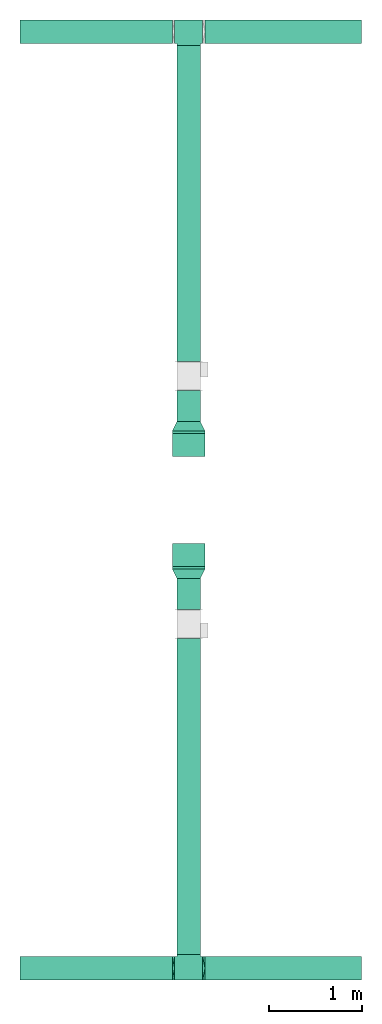
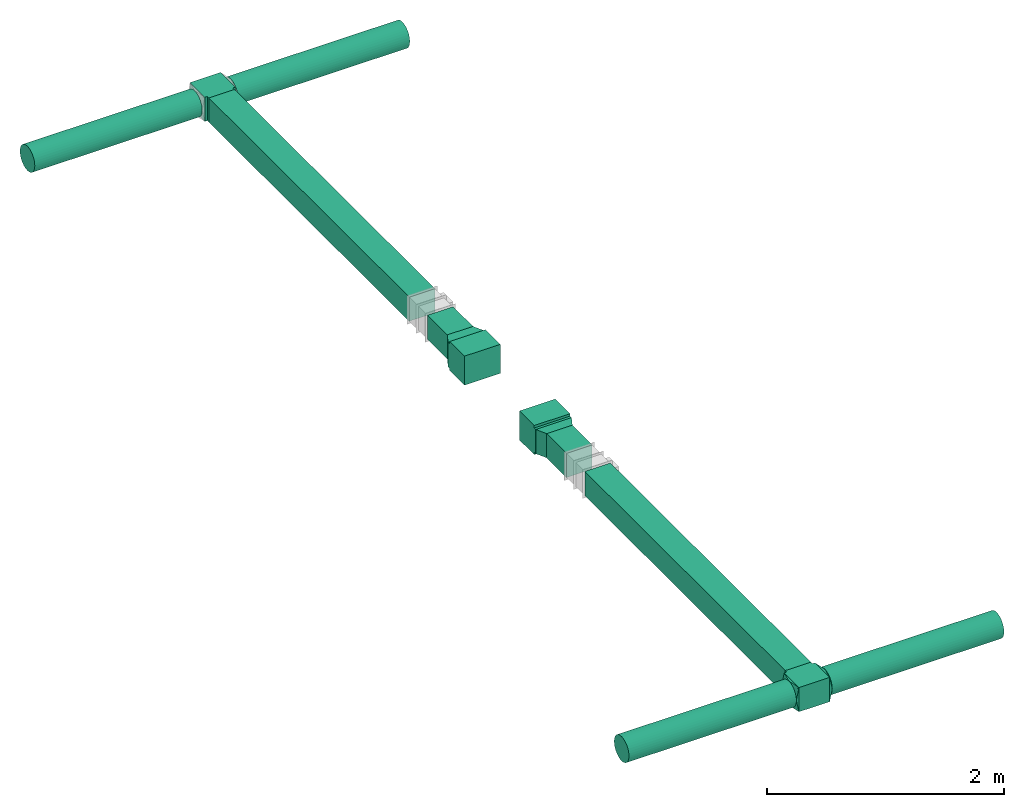
# One storey, part 1 of 3: 8 flow fittings, 8 flow segments.
"""IFC2X3 building model written with IfcOpenShell, lengths in millimetres."""

from ifc_helpers import new_model, entity, si_unit, converted_unit, derived_unit, direction, frame, frame_2d, origin, origin_2d_with_axis, place, context, subcontext, project, spatial, polyline, rectangle, circle, outline, extrude, faceted_brep, source, transform, mapped, material, type_object, type_shapes, element, save


model = new_model("IFC2X3")

# Units and contexts
model_context = context("Model", 3, precision=0.01, world=origin(), true_north=direction((6.12303176911189e-17, 1.0)))
body_context = subcontext(model_context, "Body", "Model", "MODEL_VIEW")
ifc_project = project(units=[si_unit("LENGTHUNIT", "METRE", prefix="MILLI"), si_unit("AREAUNIT", "SQUARE_METRE"), si_unit("VOLUMEUNIT", "CUBIC_METRE"), converted_unit("PLANEANGLEUNIT", "DEGREE", entity("IfcRatioMeasure", 0.0174532925199433), si_unit("PLANEANGLEUNIT", "RADIAN"), dimensions=[0, 0, 0, 0, 0, 0, 0]), si_unit("MASSUNIT", "GRAM", prefix="KILO"), derived_unit("MASSDENSITYUNIT", [(si_unit("MASSUNIT", "GRAM", prefix="KILO"), 1), (si_unit("LENGTHUNIT", "METRE"), -3)]), si_unit("TIMEUNIT", "SECOND"), si_unit("FREQUENCYUNIT", "HERTZ"), si_unit("THERMODYNAMICTEMPERATUREUNIT", "DEGREE_CELSIUS"), derived_unit("THERMALTRANSMITTANCEUNIT", [(si_unit("MASSUNIT", "GRAM", prefix="KILO"), 1), (si_unit("THERMODYNAMICTEMPERATUREUNIT", "KELVIN"), -1), (si_unit("TIMEUNIT", "SECOND"), -3)]), derived_unit("VOLUMETRICFLOWRATEUNIT", [(si_unit("LENGTHUNIT", "METRE"), 3), (si_unit("TIMEUNIT", "SECOND"), -1)]), si_unit("ELECTRICCURRENTUNIT", "AMPERE"), si_unit("ELECTRICVOLTAGEUNIT", "VOLT"), si_unit("POWERUNIT", "WATT"), si_unit("FORCEUNIT", "NEWTON", prefix="KILO"), si_unit("ILLUMINANCEUNIT", "LUX"), si_unit("LUMINOUSFLUXUNIT", "LUMEN"), si_unit("LUMINOUSINTENSITYUNIT", "CANDELA"), derived_unit("USERDEFINED", [(si_unit("MASSUNIT", "GRAM", prefix="KILO"), -1), (si_unit("LENGTHUNIT", "METRE"), -2), (si_unit("TIMEUNIT", "SECOND"), 3), (si_unit("LUMINOUSFLUXUNIT", "LUMEN"), 1)]), derived_unit("LINEARVELOCITYUNIT", [(si_unit("LENGTHUNIT", "METRE"), 1), (si_unit("TIMEUNIT", "SECOND"), -1)]), si_unit("PRESSUREUNIT", "PASCAL"), derived_unit("USERDEFINED", [(si_unit("LENGTHUNIT", "METRE"), -2), (si_unit("MASSUNIT", "GRAM", prefix="KILO"), 1), (si_unit("TIMEUNIT", "SECOND"), -2)])], contexts=[model_context])

# Site, building, storey
site_placement = place(None, origin())
site = spatial("IfcSite", under=ifc_project, at=site_placement, CompositionType="ELEMENT")
building_placement = place(site_placement, origin())
building = spatial("IfcBuilding", under=site, at=building_placement, CompositionType="ELEMENT")
storey_placement = place(building_placement, frame((0.0, 0.0, 8000.0)))
storey = spatial("IfcBuildingStorey", under=building, at=storey_placement, Name="02 Level", CompositionType="ELEMENT", Elevation=8000.0)

# Flow segments
duct_segment_type_1 = type_object("IfcDuctSegmentType", Name="Round Duct:Air", PredefinedType="NOTDEFINED")
flow_segment_1_placement = place(storey_placement, frame((24805.6615179764, -73978.4971681894, 3383.40472776408)))
element("IfcFlowSegment", 1, at=flow_segment_1_placement, inside=storey, type_object=duct_segment_type_1, Name="Round Duct:Air", ObjectType="Round Duct:Air", context=body_context, shape_type="SweptSolid", body=[
    extrude(circle(Radius=125.0, at=origin_2d_with_axis()), frame((0.0, 126.595272235913, 126.595272235916), z_axis=(1.0, 0.0, 0.0), x_axis=(0.0, -1.0, 0.0)), (0.0, 0.0, 1.0), 1675.67988537007),
])
flow_segment_2_placement = place(storey_placement, frame((22822.2515072766, -73978.4971681894, 3383.40472776408)))
element("IfcFlowSegment", 2, at=flow_segment_2_placement, inside=storey, type_object=duct_segment_type_1, Name="Round Duct:Air", ObjectType="Round Duct:Air", context=body_context, shape_type="SweptSolid", body=[
    extrude(circle(Radius=125.0, at=origin_2d_with_axis()), frame((0.0, 126.595272235913, 126.595272235916), z_axis=(1.0, 0.0, 0.0), x_axis=(0.0, -1.0, 0.0)), (0.0, 0.0, 1.0), 1633.4100106998),
])
flow_segment_3_placement = place(storey_placement, frame((24805.6615179764, -63937.1725465623, 3383.40472776408)))
element("IfcFlowSegment", 3, at=flow_segment_3_placement, inside=storey, type_object=duct_segment_type_1, Name="Round Duct:Air", ObjectType="Round Duct:Air", context=body_context, shape_type="SweptSolid", body=[
    extrude(circle(Radius=125.0, at=origin_2d_with_axis()), frame((0.0, 126.595272235922, 126.595272235916), z_axis=(1.0, 0.0, 0.0), x_axis=(0.0, -1.0, 0.0)), (0.0, 0.0, 1.0), 1675.67988537007),
])
flow_segment_4_placement = place(storey_placement, frame((22822.2515072766, -63937.1725465622, 3383.40472776408)))
element("IfcFlowSegment", 4, at=flow_segment_4_placement, inside=storey, type_object=duct_segment_type_1, Name="Round Duct:Air", ObjectType="Round Duct:Air", context=body_context, shape_type="SweptSolid", body=[
    extrude(circle(Radius=125.0, at=origin_2d_with_axis()), frame((0.0, 126.595272235922, 126.595272235916), z_axis=(1.0, 0.0, 0.0), x_axis=(0.0, -1.0, 0.0)), (0.0, 0.0, 1.0), 1633.4100106998),
])
duct_segment_type_2 = type_object("IfcDuctSegmentType", Name="Rectangular Duct:Air", PredefinedType="NOTDEFINED")
flow_segment_5_placement = place(storey_placement, frame((24505.6615179764, -70005.2893332731, 3385.0)))
element("IfcFlowSegment", 5, at=flow_segment_5_placement, inside=storey, type_object=duct_segment_type_2, Name="Rectangular Duct:Air", ObjectType="Rectangular Duct:Air", context=body_context, shape_type="SweptSolid", body=[
    extrude(rectangle(XDim=334.049748133151, YDim=249.999999999999, at=frame_2d((4.33431068813661e-12, 2.16715534406831e-12), x_axis=(1.0, 0.0))), frame((125.0, 167.02487406658, 0.0), z_axis=(0.0, 0.0, 1.0), x_axis=(0.0, 1.0, 0.0)), (0.0, 0.0, 1.0), 249.999999999999),
])
flow_segment_6_placement = place(storey_placement, frame((24505.6615179764, -73701.9018959535, 3385.0)))
element("IfcFlowSegment", 6, at=flow_segment_6_placement, inside=storey, type_object=duct_segment_type_2, Name="Rectangular Duct:Air", ObjectType="Rectangular Duct:Air", context=body_context, shape_type="SweptSolid", body=[
    extrude(rectangle(XDim=3386.61256268045, YDim=249.999999999999, at=frame_2d((4.32009983342141e-12, 0.0), x_axis=(1.0, 0.0))), frame((125.0, 1693.30628134022, 0.0), z_axis=(0.0, 0.0, 1.0), x_axis=(0.0, 1.0, 0.0)), (0.0, 0.0, 1.0), 249.999999999999),
])
flow_segment_7_placement = place(storey_placement, frame((24505.6615179764, -67991.2395851399, 3385.0)))
element("IfcFlowSegment", 7, at=flow_segment_7_placement, inside=storey, type_object=duct_segment_type_2, Name="Rectangular Duct:Air", ObjectType="Rectangular Duct:Air", context=body_context, shape_type="SweptSolid", body=[
    extrude(rectangle(XDim=334.049748133151, YDim=249.999999999999, at=frame_2d((8.66862137627322e-12, 0.0), x_axis=(1.0, 0.0))), frame((125.0, 167.024874066589, 0.0), z_axis=(0.0, 0.0, 1.0), x_axis=(0.0, -1.0, 0.0)), (0.0, 0.0, 1.0), 249.999999999999),
])
flow_segment_8_placement = place(storey_placement, frame((24505.6615179764, -67347.1898370068, 3385.0)))
element("IfcFlowSegment", 8, at=flow_segment_8_placement, inside=storey, type_object=duct_segment_type_2, Name="Rectangular Duct:Air", ObjectType="Rectangular Duct:Air", context=body_context, shape_type="SweptSolid", body=[
    extrude(rectangle(XDim=3386.61256268045, YDim=249.999999999999, at=frame_2d((4.32009983342141e-12, 2.16715534406831e-12), x_axis=(1.0, 0.0))), frame((125.0, 1693.30628134022, 0.0), z_axis=(0.0, 0.0, 1.0), x_axis=(0.0, -1.0, 0.0)), (0.0, 0.0, 1.0), 249.999999999999),
])

# Flow fittings
duct_fitting_type_1 = type_object("IfcDuctFittingType", Name="Air_Rect", PredefinedType="NOTDEFINED")
shared_shape_1 = source(origin(), body_context, "Body", "SweptSolid", [
    extrude(outline(polyline([(-150.0, 56.2500000000001), (-150.0, -193.75), (150.0, -193.75), (150.0, 56.25), (125.0, 56.25), (125.0, 81.2499999999995), (-125.0, 81.2500000000003), (-125.0, 56.2500000000001), (-150.0, 56.2500000000001)])), frame((0.0, -68.75, -125.0), z_axis=(0.0, 0.0, -1.0), x_axis=(1.0, 0.0, 0.0)), (0.0, 0.0, -1.0), 250.0),
])
type_shapes(duct_fitting_type_1, [shared_shape_1])
flow_fitting_1_placement = place(storey_placement, frame((24630.6615179764, -73851.9018959535, 3510.0), z_axis=(0.0, 0.0, 1.0), x_axis=(-1.0, 0.0, 0.0)))
element("IfcFlowFitting", 9, at=flow_fitting_1_placement, inside=storey, type_object=duct_fitting_type_1, Name="1_001:Air_Rect", ObjectType="1_001:Air_Rect", context=body_context, shape_type="MappedRepresentation", body=[
    mapped(shared_shape_1, transform((0.0, 0.0, 0.0), scale=1.0)),
])
ifc_material_1 = material(Name="Material_Duct")
duct_fitting_type_2 = type_object("IfcDuctFittingType", Name="Air_Multi shape transition_Circ", PredefinedType="NOTDEFINED", material=ifc_material_1)
shared_shape_2 = source(origin(), body_context, "Body", "Brep", [
    faceted_brep([(25.0, -38.627124296869, -118.882064536893), (25.0, -23.8439039196152, -121.223496622539), (25.0, -11.9219519598079, -123.111748311269), (25.0, -5.96097597990422, -124.055874155634), (25.0, 0.0, -125.0), (25.0, 5.9609759747813, -124.055874156445), (25.0, 11.9219519495628, -123.111748312892), (25.0, 23.8439038991258, -121.223496625784), (25.0, 38.6271242968683, -118.882064536893), (25.0, 56.0501404167137, -110.00459441688), (25.0, 73.4731565365591, -101.127124296868), (25.0, 87.3001404167137, -87.3001404167129), (25.0, 101.127124296868, -73.4731565365583), (25.0, 110.004594416881, -56.0501404167129), (25.0, 118.882064536894, -38.6271242968675), (25.0, 121.22349662254, -23.8439039196137), (25.0, 123.11174831127, -11.9219519598064), (25.0, 124.055874155635, -5.96097597990274), (25.0, 125.0, 0.0), (25.0, 124.055874156446, 5.96097597478117), (25.0, 123.111748312892, 11.9219519495627), (25.0, 121.223496625785, 23.8439038991257), (25.0, 118.882064536894, 38.6271242968681), (25.0, 110.004594416881, 56.0501404167135), (25.0, 101.127124296869, 73.4731565365589), (25.0, 87.300140416714, 87.3001404167136), (25.0, 73.4731565365594, 101.127124296868), (25.0, 56.050140416714, 110.004594416881), (25.0, 38.6271242968687, 118.882064536894), (25.0, 23.8439039196148, 121.22349662254), (25.0, 11.9219519598075, 123.11174831127), (25.0, 5.96097597990388, 124.055874155635), (25.0, 0.0, 125.0), (25.0, -5.96097597478126, 124.055874156446), (25.0, -11.9219519495628, 123.111748312892), (25.0, -23.8439038991258, 121.223496625785), (25.0, -38.6271242968682, 118.882064536894), (25.0, -56.0501404167136, 110.004594416881), (25.0, -73.473156536559, 101.127124296869), (25.0, -87.3001404167137, 87.3001404167139), (25.0, -101.127124296868, 73.4731565365593), (25.0, -110.004594416881, 56.0501404167139), (25.0, -118.882064536894, 38.6271242968685), (25.0, -121.22349662254, 23.8439039196147), (25.0, -123.11174831127, 11.9219519598073), (25.0, -124.055874155635, 5.96097597990369), (25.0, -125.0, 0.0), (25.0, -124.055874156446, -5.96097597478013), (25.0, -123.111748312892, -11.9219519495616), (25.0, -121.223496625785, -23.8439038991246), (25.0, -118.882064536894, -38.6271242968671), (25.0, -110.004594416882, -56.0501404167124), (25.0, -101.127124296869, -73.4731565365578), (25.0, -87.3001404167141, -87.3001404167125), (25.0, -73.4731565365595, -101.127124296867), (25.0, -56.0501404167142, -110.00459441688), (0.0, -125.0, 125.0), (0.0, 125.0, 125.0), (0.0, 125.0, -125.0), (0.0, -125.0, -125.0), (13.0142783389037, -59.9286083054818, 125.0), (12.4999999334883, -103.93826768006, 109.288032538106), (3.25356958472593, -108.732152076371, 125.0), (9.76070875417778, -76.1964562291116, 125.0), (6.50713916945186, -92.4643041527413, 125.0), (23.501784792363, -7.49107603818501, 125.0), (22.0035695847259, -14.9821520763703, 125.0), (19.0071391694519, -29.9643041527408, 125.0), (16.0107087541778, -44.9464562291113, 125.0), (6.50713897169544, -125.0, 92.464305141524), (9.76070845754317, -125.0, 76.1964577122852), (13.0142779433909, -125.0, 59.9286102830464), (16.0107084575432, -125.0, 44.9464577122848), (19.0071389716954, -125.0, 29.9643051415232), (22.0035694858477, -125.0, 14.9821525707616), (23.5017847429239, -125.0, 7.49107628538082), (3.25356948584772, -125.0, 108.732152570763), (3.25356958472593, -125.0, -108.73215207637), (6.50713916945185, -125.0, -92.4643041527404), (9.76070875417777, -125.0, -76.1964562291106), (13.0142783389037, -125.0, -59.9286083054808), (16.0107087541778, -125.0, -44.9464562291103), (19.0071391694518, -125.0, -29.9643041527397), (22.0035695847259, -125.0, -14.9821520763692), (23.501784792363, -125.0, -7.4910760381839), (12.4999999334883, -109.288032538106, -103.938267680059), (6.50713897169543, -92.4643051415237, -125.0), (9.76070845754315, -76.196457712285, -125.0), (13.0142779433909, -59.9286102830464, -125.0), (16.0107084575432, -44.9464577122849, -125.0), (19.0071389716954, -29.9643051415235, -125.0), (22.0035694858477, -14.982152570762, -125.0), (23.5017847429239, -7.49107628538127, -125.0), (3.25356948584772, -108.732152570762, -125.0), (3.25356958472593, 108.73215207637, -125.0), (6.50713916945186, 92.4643041527402, -125.0), (9.76070875417778, 76.1964562291106, -125.0), (13.0142783389037, 59.9286083054811, -125.0), (16.0107087541778, 44.9464562291108, -125.0), (19.0071391694519, 29.9643041527404, -125.0), (22.0035695847259, 14.9821520763701, -125.0), (23.501784792363, 7.49107603818496, -125.0), (12.4999999334883, 103.938267680059, -109.288032538105), (6.50713897169544, 125.0, -92.4643051415225), (9.76070845754317, 125.0, -76.1964577122838), (13.0142779433909, 125.0, -59.9286102830451), (16.0107084575432, 125.0, -44.9464577122836), (19.0071389716954, 125.0, -29.9643051415221), (22.0035694858477, 125.0, -14.9821525707606), (23.5017847429239, 125.0, -7.49107628537983), (3.25356948584772, 125.0, -108.732152570761), (3.25356958472593, 125.0, 108.732152076372), (6.50713916945185, 125.0, 92.4643041527418), (9.76070875417778, 125.0, 76.196456229112), (13.0142783389037, 125.0, 59.9286083054821), (16.0107087541778, 125.0, 44.9464562291115), (19.0071391694519, 125.0, 29.9643041527409), (22.0035695847259, 125.0, 14.9821520763703), (23.501784792363, 125.0, 7.49107603818497), (12.4999999334883, 109.288032538105, 103.93826768006), (6.50713897169544, 92.4643051415224, 125.0), (9.76070845754316, 76.1964577122839, 125.0), (13.0142779433909, 59.9286102830454, 125.0), (16.0107084575432, 44.9464577122841, 125.0), (19.0071389716954, 29.9643051415228, 125.0), (22.0035694858477, 14.9821525707615, 125.0), (23.5017847429239, 7.49107628538087, 125.0), (3.25356948584772, 108.732152570761, 125.0)], [[[0, 1, 2, 3, 4, 5, 6, 7, 8, 9, 10, 11, 12, 13, 14, 15, 16, 17, 18, 19, 20, 21, 22, 23, 24, 25, 26, 27, 28, 29, 30, 31, 32, 33, 34, 35, 36, 37, 38, 39, 40, 41, 42, 43, 44, 45, 46, 47, 48, 49, 50, 51, 52, 53, 54, 55]], [[56, 57, 58, 59]], [[60, 37, 36]], [[56, 61, 62]], [[37, 60, 63, 64]], [[65, 66, 67, 68, 60, 36, 35, 34, 33, 32]], [[62, 61, 38]], [[41, 69, 70, 71]], [[64, 38, 37]], [[42, 71, 72, 73, 74, 75, 46, 45, 44, 43]], [[40, 76, 69]], [[71, 42, 41]], [[61, 76, 39]], [[38, 64, 62]], [[76, 40, 39]], [[38, 61, 39]], [[61, 56, 76]], [[69, 41, 40]], [[56, 59, 77, 78, 79, 80, 81, 82, 83, 84, 46, 75, 74, 73, 72, 71, 70, 69, 76]], [[80, 51, 50]], [[59, 85, 77]], [[51, 80, 79, 78]], [[84, 83, 82, 81, 80, 50, 49, 48, 47, 46]], [[77, 85, 52]], [[55, 86, 87, 88]], [[78, 52, 51]], [[0, 88, 89, 90, 91, 92, 4, 3, 2, 1]], [[54, 93, 86]], [[88, 0, 55]], [[85, 93, 53]], [[52, 78, 77]], [[93, 54, 53]], [[52, 85, 53]], [[85, 59, 93]], [[86, 55, 54]], [[92, 91, 90, 89, 88, 87, 86, 93, 59, 58, 94, 95, 96, 97, 98, 99, 100, 101, 4]], [[97, 9, 8]], [[58, 102, 94]], [[9, 97, 96, 95]], [[101, 100, 99, 98, 97, 8, 7, 6, 5, 4]], [[94, 102, 10]], [[13, 103, 104, 105]], [[95, 10, 9]], [[14, 105, 106, 107, 108, 109, 18, 17, 16, 15]], [[12, 110, 103]], [[105, 14, 13]], [[102, 110, 11]], [[10, 95, 94]], [[110, 12, 11]], [[10, 102, 11]], [[102, 58, 110]], [[103, 13, 12]], [[58, 57, 111, 112, 113, 114, 115, 116, 117, 118, 18, 109, 108, 107, 106, 105, 104, 103, 110]], [[114, 23, 22]], [[57, 119, 111]], [[23, 114, 113, 112]], [[118, 117, 116, 115, 114, 22, 21, 20, 19, 18]], [[111, 119, 24]], [[27, 120, 121, 122]], [[112, 24, 23]], [[28, 122, 123, 124, 125, 126, 32, 31, 30, 29]], [[26, 127, 120]], [[122, 28, 27]], [[119, 127, 25]], [[24, 112, 111]], [[127, 26, 25]], [[24, 119, 25]], [[119, 57, 127]], [[120, 27, 26]], [[57, 56, 62, 64, 63, 60, 68, 67, 66, 65, 32, 126, 125, 124, 123, 122, 121, 120, 127]]]),
])
type_shapes(duct_fitting_type_2, [shared_shape_2])
flow_fitting_2_placement = place(storey_placement, frame((24480.6615179764, -73851.9018959535, 3510.0), z_axis=(0.0, 0.0, 1.0), x_axis=(-1.0, 0.0, 0.0)))
element("IfcFlowFitting", 10, at=flow_fitting_2_placement, inside=storey, type_object=duct_fitting_type_2, material=ifc_material_1, Name="multi_shape_trans_001:Air_Multi shape transition_Circ", ObjectType="multi_shape_trans_001:Air_Multi shape transition_Circ", context=body_context, shape_type="MappedRepresentation", body=[
    mapped(shared_shape_2, transform((0.0, 0.0, 0.0), scale=1.0)),
])
flow_fitting_3_placement = place(storey_placement, frame((24780.6615179764, -73851.9018959535, 3510.0)))
element("IfcFlowFitting", 11, at=flow_fitting_3_placement, inside=storey, type_object=duct_fitting_type_2, material=ifc_material_1, Name="multi_shape_trans_001:Air_Multi shape transition_Circ", ObjectType="multi_shape_trans_001:Air_Multi shape transition_Circ", context=body_context, shape_type="MappedRepresentation", body=[
    mapped(shared_shape_2, transform((0.0, 0.0, 0.0), scale=1.0)),
])
duct_fitting_type_3 = type_object("IfcDuctFittingType", Name="Air_Rect", PredefinedType="NOTDEFINED")
shared_shape_3 = source(origin(), body_context, "Body", "SweptSolid", [
    extrude(outline(polyline([(-150.0, 56.2500000000001), (-150.0, -193.75), (150.0, -193.75), (150.0, 56.25), (125.0, 56.25), (125.0, 81.2499999999995), (-125.0, 81.2500000000003), (-125.0, 56.2500000000001), (-150.0, 56.2500000000001)])), frame((0.0, -68.75, -175.0), z_axis=(0.0, 0.0, -1.0), x_axis=(1.0, 0.0, 0.0)), (0.0, 0.0, -1.0), 350.0),
])
type_shapes(duct_fitting_type_3, [shared_shape_3])
flow_fitting_4_placement = place(storey_placement, frame((24630.6615179764, -69421.2395851399, 3510.0), z_axis=(1.0, 0.0, 0.0), x_axis=(0.0, 0.0, -1.0)))
element("IfcFlowFitting", 12, at=flow_fitting_4_placement, inside=storey, type_object=duct_fitting_type_3, Name="1_001:Air_Rect", ObjectType="1_001:Air_Rect", context=body_context, shape_type="MappedRepresentation", body=[
    mapped(shared_shape_3, transform((0.0, 0.0, 0.0), scale=1.0)),
])
ifc_material_2 = material(Name="DF_Material1")
duct_fitting_type_4 = type_object("IfcDuctFittingType", Name="Air_LRD", PredefinedType="NOTDEFINED", material=ifc_material_2)
shared_shape_4 = source(origin(), body_context, "Body", "SweptSolid", [
    extrude(rectangle(XDim=2.0, YDim=350.0, at=origin_2d_with_axis()), frame((99.0, 0.0, -125.0), z_axis=(0.0, 0.0, 1.0), x_axis=(-1.0, 0.0, 0.0)), (0.0, 0.0, 1.0), 250.0),
    extrude(rectangle(XDim=2.0, YDim=250.0, at=origin_2d_with_axis()), frame((1.0, 0.0, -125.0), z_axis=(0.0, 0.0, 1.0), x_axis=(-1.0, 0.0, 0.0)), (0.0, 0.0, 1.0), 250.0),
    extrude(outline(polyline([(11.1803398874972, -134.164078649989), (122.983738762486, -134.164078649988), (-33.5410196624944, 178.885438199985), (-100.623058987489, 89.4427190999923), (11.1803398874972, -134.164078649989)])), frame((50.0, 0.0, -125.0), z_axis=(0.0, 0.0, 1.0), x_axis=(0.894427190999923, -0.447213595499945, 0.0)), (0.0, 0.0, 1.0), 250.0),
])
type_shapes(duct_fitting_type_4, [shared_shape_4])
flow_fitting_5_placement = place(storey_placement, frame((24630.6615179763, -69671.2395851399, 3510.0), z_axis=(0.0, 0.0, 1.0), x_axis=(0.0, 1.0, 0.0)))
element("IfcFlowFitting", 13, at=flow_fitting_5_placement, inside=storey, type_object=duct_fitting_type_4, material=ifc_material_2, Name="LDR:Air", ObjectType="LDR:Air_LRD", context=body_context, shape_type="MappedRepresentation", body=[
    mapped(shared_shape_4, transform((0.0, 0.0, 0.0), scale=1.0)),
])
duct_fitting_type_5 = type_object("IfcDuctFittingType", Name="Air_Rect", PredefinedType="NOTDEFINED")
shared_shape_5 = source(origin(), body_context, "Body", "SweptSolid", [
    extrude(outline(polyline([(-56.2499999999996, -150.0), (193.75, -150.0), (193.75, 150.0), (-56.2500000000005, 150.0), (-56.2500000000004, 125.0), (-81.2499999999999, 125.0), (-81.2499999999999, -125.0), (-56.2499999999996, -125.0), (-56.2499999999996, -150.0)])), frame((0.0, 68.75, -125.0), z_axis=(0.0, 0.0, 1.0), x_axis=(0.0, -1.0, 0.0)), (0.0, 0.0, 1.0), 250.0),
])
type_shapes(duct_fitting_type_5, [shared_shape_5])
flow_fitting_6_placement = place(storey_placement, frame((24630.6615179764, -63810.5772743263, 3510.0), z_axis=(0.0, 0.0, 1.0), x_axis=(-1.0, 0.0, 0.0)))
element("IfcFlowFitting", 14, at=flow_fitting_6_placement, inside=storey, type_object=duct_fitting_type_5, Name="1_001:Air_Rect", ObjectType="1_001:Air_Rect", context=body_context, shape_type="MappedRepresentation", body=[
    mapped(shared_shape_5, transform((0.0, 0.0, 0.0), scale=1.0)),
])
duct_fitting_type_6 = type_object("IfcDuctFittingType", Name="Air_Rect", PredefinedType="NOTDEFINED")
shared_shape_6 = source(origin(), body_context, "Body", "SweptSolid", [
    extrude(outline(polyline([(-56.2499999999996, -150.0), (193.75, -150.0), (193.75, 150.0), (-56.2500000000005, 150.0), (-56.2500000000004, 125.0), (-81.2499999999999, 125.0), (-81.2499999999999, -125.0), (-56.2499999999996, -125.0), (-56.2499999999996, -150.0)])), frame((0.0, 68.75, -175.0), z_axis=(0.0, 0.0, 1.0), x_axis=(0.0, -1.0, 0.0)), (0.0, 0.0, 1.0), 350.0),
])
type_shapes(duct_fitting_type_6, [shared_shape_6])
flow_fitting_7_placement = place(storey_placement, frame((24630.6615179764, -68241.2395851399, 3510.0), z_axis=(1.0, 0.0, 0.0), x_axis=(0.0, 0.0, -1.0)))
element("IfcFlowFitting", 15, at=flow_fitting_7_placement, inside=storey, type_object=duct_fitting_type_6, Name="1_001:Air_Rect", ObjectType="1_001:Air_Rect", context=body_context, shape_type="MappedRepresentation", body=[
    mapped(shared_shape_6, transform((0.0, 0.0, 0.0), scale=1.0)),
])
duct_fitting_type_7 = type_object("IfcDuctFittingType", Name="Air_LRD", PredefinedType="NOTDEFINED", material=ifc_material_2)
shared_shape_7 = source(origin(), body_context, "Body", "SweptSolid", [
    extrude(rectangle(XDim=350.0, YDim=2.0, at=origin_2d_with_axis()), frame((99.0, 0.0, -125.0), z_axis=(0.0, 0.0, 1.0), x_axis=(0.0, 1.0, 0.0)), (0.0, 0.0, 1.0), 250.0),
    extrude(rectangle(XDim=250.0, YDim=2.0, at=origin_2d_with_axis()), frame((1.0, 0.0, -125.0), z_axis=(0.0, 0.0, 1.0), x_axis=(0.0, 1.0, 0.0)), (0.0, 0.0, 1.0), 250.0),
    extrude(outline(polyline([(-125.0, -50.0), (125.0, -50.0), (175.0, 50.0), (-175.0, 50.0), (-125.0, -50.0)])), frame((50.0, 0.0, -125.0), z_axis=(0.0, 0.0, 1.0), x_axis=(0.0, -1.0, 0.0)), (0.0, 0.0, 1.0), 250.0),
])
type_shapes(duct_fitting_type_7, [shared_shape_7])
flow_fitting_8_placement = place(storey_placement, frame((24630.6615179763, -67991.2395851399, 3510.0), z_axis=(0.0, 0.0, 1.0), x_axis=(0.0, -1.0, 0.0)))
element("IfcFlowFitting", 16, at=flow_fitting_8_placement, inside=storey, type_object=duct_fitting_type_7, material=ifc_material_2, Name="LDR:Air", ObjectType="LDR:Air_LRD", context=body_context, shape_type="MappedRepresentation", body=[
    mapped(shared_shape_7, transform((0.0, 0.0, 0.0), scale=1.0)),
])

save(model, "model.ifc")
